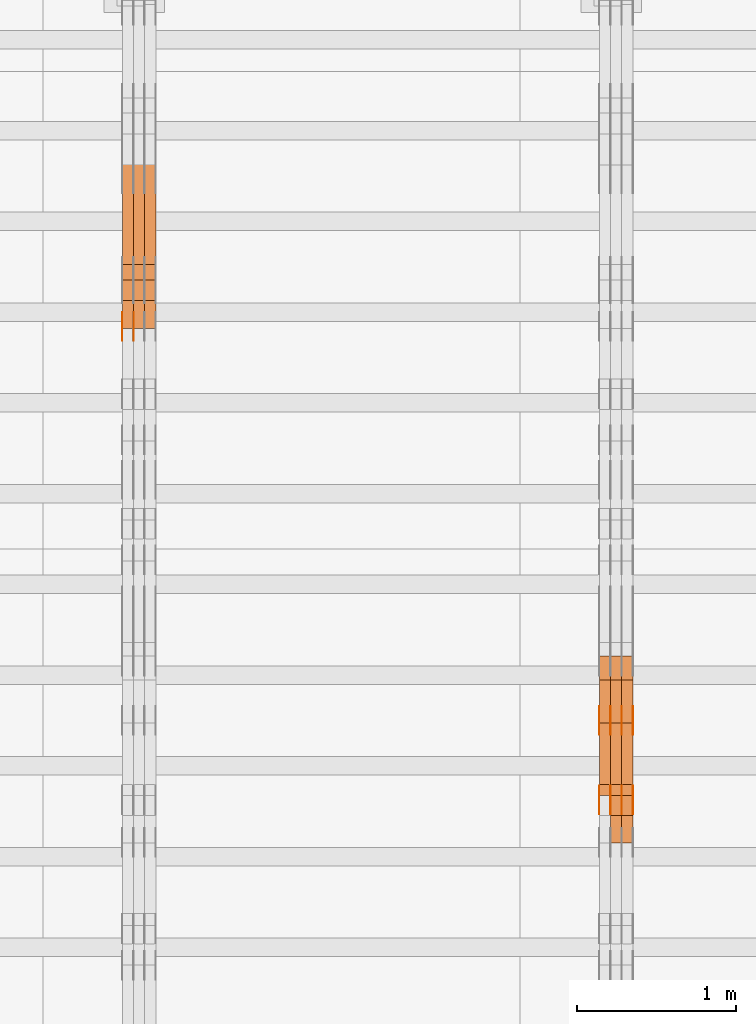
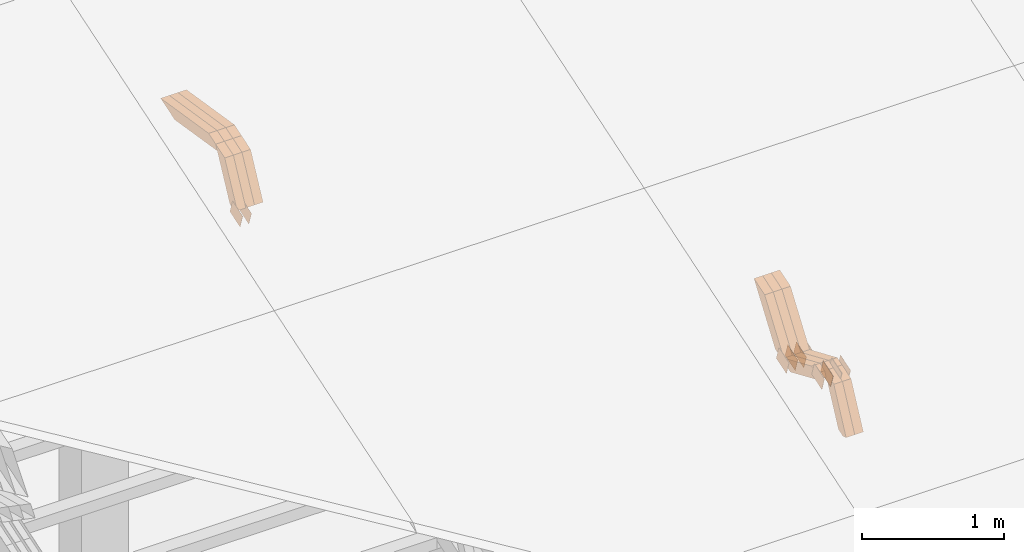
# One storey, part 138 of 385: 28 proxies.
"""IFC2X3 building model written with IfcOpenShell, lengths in millimetres."""

from ifc_helpers import new_model, entity, si_unit, converted_unit, derived_unit, direction, frame, origin, place, context, subcontext, project, spatial, polyline, outline, extrude, source, transform, mapped, material, type_object, type_shapes, element, save


model = new_model("IFC2X3")

# Units and contexts
model_context = context("Model", 3, precision=0.01, world=origin(), true_north=direction((6.12303176911189e-17, 1.0)))
body_context = subcontext(model_context, "Body", "Model", "MODEL_VIEW")
ifc_project = project(units=[si_unit("LENGTHUNIT", "METRE", prefix="MILLI"), si_unit("AREAUNIT", "SQUARE_METRE"), si_unit("VOLUMEUNIT", "CUBIC_METRE"), converted_unit("PLANEANGLEUNIT", "DEGREE", entity("IfcRatioMeasure", 0.0174532925199433), si_unit("PLANEANGLEUNIT", "RADIAN"), dimensions=[0, 0, 0, 0, 0, 0, 0]), si_unit("MASSUNIT", "GRAM", prefix="KILO"), derived_unit("MASSDENSITYUNIT", [(si_unit("MASSUNIT", "GRAM", prefix="KILO"), 1), (si_unit("LENGTHUNIT", "METRE"), -3)]), si_unit("TIMEUNIT", "SECOND"), si_unit("FREQUENCYUNIT", "HERTZ"), si_unit("THERMODYNAMICTEMPERATUREUNIT", "DEGREE_CELSIUS"), derived_unit("THERMALTRANSMITTANCEUNIT", [(si_unit("MASSUNIT", "GRAM", prefix="KILO"), 1), (si_unit("THERMODYNAMICTEMPERATUREUNIT", "KELVIN"), -1), (si_unit("TIMEUNIT", "SECOND"), -3)]), derived_unit("VOLUMETRICFLOWRATEUNIT", [(si_unit("LENGTHUNIT", "METRE"), 3), (si_unit("TIMEUNIT", "SECOND"), -1)]), si_unit("ELECTRICCURRENTUNIT", "AMPERE"), si_unit("ELECTRICVOLTAGEUNIT", "VOLT"), si_unit("POWERUNIT", "WATT"), si_unit("FORCEUNIT", "NEWTON", prefix="KILO"), si_unit("ILLUMINANCEUNIT", "LUX"), si_unit("LUMINOUSFLUXUNIT", "LUMEN"), si_unit("LUMINOUSINTENSITYUNIT", "CANDELA"), derived_unit("USERDEFINED", [(si_unit("MASSUNIT", "GRAM", prefix="KILO"), -1), (si_unit("LENGTHUNIT", "METRE"), -2), (si_unit("TIMEUNIT", "SECOND"), 3), (si_unit("LUMINOUSFLUXUNIT", "LUMEN"), 1)]), derived_unit("LINEARVELOCITYUNIT", [(si_unit("LENGTHUNIT", "METRE"), 1), (si_unit("TIMEUNIT", "SECOND"), -1)]), si_unit("PRESSUREUNIT", "PASCAL"), derived_unit("USERDEFINED", [(si_unit("LENGTHUNIT", "METRE"), -2), (si_unit("MASSUNIT", "GRAM", prefix="KILO"), 1), (si_unit("TIMEUNIT", "SECOND"), -2)])], contexts=[model_context])

# Site, building, storey
site_placement = place(None, origin())
site = spatial("IfcSite", under=ifc_project, at=site_placement, CompositionType="ELEMENT")
building_placement = place(site_placement, origin())
building = spatial("IfcBuilding", under=site, at=building_placement, CompositionType="ELEMENT")
storey_placement = place(building_placement, origin())
storey = spatial("IfcBuildingStorey", under=building, at=storey_placement, Name="Default", CompositionType="ELEMENT", Elevation=0.0)

# Proxies
ifc_material_1 = material(Name="IfcSurfaceStyle #379932")
building_element_proxy_type_1 = type_object("IfcBuildingElementProxyType", PredefinedType="NOTDEFINED", material=ifc_material_1)
shared_shape_1 = source(origin(), body_context, "Body", "SweptSolid", [
    extrude(outline(polyline([(-74.9998565677169, -60.0000596852269), (74.9998794200137, -60.0000596852269), (74.9998565677151, 60.0000596852269), (-74.9998794200119, 60.0000596852269), (-74.9998565677169, -60.0000596852269)])), frame((74.9998794200137, 60.0000596852269, 0.0), z_axis=(0.0, 0.0, 1.0), x_axis=(-1.0, 0.0, 0.0)), (0.0, 0.0, 1.0), 1.3),
])
type_shapes(building_element_proxy_type_1, [shared_shape_1])
proxy_1_placement = place(building_placement, frame((30386.3, 7527.6269081625, 1621.97418552253), z_axis=(-1.0, 0.0, 0.0), x_axis=(0.0, 0.951056516295124, 0.309016994375039)))
element("IfcBuildingElementProxy", 1, at=proxy_1_placement, inside=storey, type_object=building_element_proxy_type_1, material=ifc_material_1, context=body_context, shape_type="MappedRepresentation", body=[
    mapped(shared_shape_1, transform((0.0, 0.0, 0.0), scale=1.0)),
])
ifc_material_2 = material(Name="IfcSurfaceStyle #379875")
building_element_proxy_type_2 = type_object("IfcBuildingElementProxyType", PredefinedType="NOTDEFINED", material=ifc_material_2)
shared_shape_2 = source(origin(), body_context, "Body", "SweptSolid", [
    extrude(outline(polyline([(-74.9998565677169, -60.0000596852269), (74.9998794200137, -60.0000596852269), (74.9998565677151, 60.0000596852269), (-74.9998794200119, 60.0000596852269), (-74.9998565677169, -60.0000596852269)])), frame((74.9998794200137, 60.0000596852269, 0.0), z_axis=(0.0, 0.0, 1.0), x_axis=(-1.0, 0.0, 0.0)), (0.0, 0.0, 1.0), 1.3),
])
type_shapes(building_element_proxy_type_2, [shared_shape_2])
proxy_2_placement = place(building_placement, frame((30315.0, 7527.6269081625, 1621.97418552253), z_axis=(-1.0, 0.0, 0.0), x_axis=(0.0, 0.951056516295124, 0.309016994375039)))
element("IfcBuildingElementProxy", 2, at=proxy_2_placement, inside=storey, type_object=building_element_proxy_type_2, material=ifc_material_2, context=body_context, shape_type="MappedRepresentation", body=[
    mapped(shared_shape_2, transform((0.0, 0.0, 0.0), scale=1.0)),
])
ifc_material_3 = material(Name="IfcSurfaceStyle #379818")
building_element_proxy_type_3 = type_object("IfcBuildingElementProxyType", PredefinedType="NOTDEFINED", material=ifc_material_3)
shared_shape_3 = source(origin(), body_context, "Body", "SweptSolid", [
    extrude(outline(polyline([(-74.9998565677169, -60.0000596852269), (74.9998794200137, -60.0000596852269), (74.9998565677151, 60.0000596852269), (-74.9998794200119, 60.0000596852269), (-74.9998565677169, -60.0000596852269)])), frame((74.9998794200137, 60.0000596852269, 0.0), z_axis=(0.0, 0.0, 1.0), x_axis=(-1.0, 0.0, 0.0)), (0.0, 0.0, 1.0), 1.3),
])
type_shapes(building_element_proxy_type_3, [shared_shape_3])
proxy_3_placement = place(building_placement, frame((30316.3, 7527.6269081625, 1621.97418552253), z_axis=(-1.0, 0.0, 0.0), x_axis=(0.0, 0.951056516295124, 0.309016994375039)))
element("IfcBuildingElementProxy", 3, at=proxy_3_placement, inside=storey, type_object=building_element_proxy_type_3, material=ifc_material_3, context=body_context, shape_type="MappedRepresentation", body=[
    mapped(shared_shape_3, transform((0.0, 0.0, 0.0), scale=1.0)),
])
ifc_material_4 = material(Name="IfcSurfaceStyle #379761")
building_element_proxy_type_4 = type_object("IfcBuildingElementProxyType", PredefinedType="NOTDEFINED", material=ifc_material_4)
shared_shape_4 = source(origin(), body_context, "Body", "SweptSolid", [
    extrude(outline(polyline([(-74.9998565677169, -60.0000596852269), (74.9998794200137, -60.0000596852269), (74.9998565677151, 60.0000596852269), (-74.9998794200119, 60.0000596852269), (-74.9998565677169, -60.0000596852269)])), frame((74.9998794200137, 60.0000596852269, 0.0), z_axis=(0.0, 0.0, 1.0), x_axis=(-1.0, 0.0, 0.0)), (0.0, 0.0, 1.0), 1.29999999999999),
])
type_shapes(building_element_proxy_type_4, [shared_shape_4])
proxy_4_placement = place(building_placement, frame((30245.0, 7527.6269081625, 1621.97418552253), z_axis=(-1.0, 0.0, 0.0), x_axis=(0.0, 0.951056516295124, 0.309016994375039)))
element("IfcBuildingElementProxy", 4, at=proxy_4_placement, inside=storey, type_object=building_element_proxy_type_4, material=ifc_material_4, context=body_context, shape_type="MappedRepresentation", body=[
    mapped(shared_shape_4, transform((0.0, 0.0, 0.0), scale=1.0)),
])
ifc_material_5 = material(Name="IfcSurfaceStyle #379704")
building_element_proxy_type_5 = type_object("IfcBuildingElementProxyType", PredefinedType="NOTDEFINED", material=ifc_material_5)
shared_shape_5 = source(origin(), body_context, "Body", "SweptSolid", [
    extrude(outline(polyline([(-74.9998565677169, -60.0000596852269), (74.9998794200137, -60.0000596852269), (74.9998565677151, 60.0000596852269), (-74.9998794200119, 60.0000596852269), (-74.9998565677169, -60.0000596852269)])), frame((74.9998794200137, 60.0000596852269, 0.0), z_axis=(0.0, 0.0, 1.0), x_axis=(-1.0, 0.0, 0.0)), (0.0, 0.0, 1.0), 1.29999999999999),
])
type_shapes(building_element_proxy_type_5, [shared_shape_5])
proxy_5_placement = place(building_placement, frame((30246.3, 7527.6269081625, 1621.97418552253), z_axis=(-1.0, 0.0, 0.0), x_axis=(0.0, 0.951056516295124, 0.309016994375039)))
element("IfcBuildingElementProxy", 5, at=proxy_5_placement, inside=storey, type_object=building_element_proxy_type_5, material=ifc_material_5, context=body_context, shape_type="MappedRepresentation", body=[
    mapped(shared_shape_5, transform((0.0, 0.0, 0.0), scale=1.0)),
])
ifc_material_6 = material(Name="IfcSurfaceStyle #379647")
building_element_proxy_type_6 = type_object("IfcBuildingElementProxyType", PredefinedType="NOTDEFINED", material=ifc_material_6)
shared_shape_6 = source(origin(), body_context, "Body", "SweptSolid", [
    extrude(outline(polyline([(-74.9998565677169, -60.0000596852269), (74.9998794200137, -60.0000596852269), (74.9998565677151, 60.0000596852269), (-74.9998794200119, 60.0000596852269), (-74.9998565677169, -60.0000596852269)])), frame((74.9998794200137, 60.0000596852269, 0.0), z_axis=(0.0, 0.0, 1.0), x_axis=(-1.0, 0.0, 0.0)), (0.0, 0.0, 1.0), 1.29999999999999),
])
type_shapes(building_element_proxy_type_6, [shared_shape_6])
proxy_6_placement = place(building_placement, frame((30175.0, 7527.6269081625, 1621.97418552253), z_axis=(-1.0, 0.0, 0.0), x_axis=(0.0, 0.951056516295124, 0.309016994375039)))
element("IfcBuildingElementProxy", 6, at=proxy_6_placement, inside=storey, type_object=building_element_proxy_type_6, material=ifc_material_6, context=body_context, shape_type="MappedRepresentation", body=[
    mapped(shared_shape_6, transform((0.0, 0.0, 0.0), scale=1.0)),
])
ifc_material_7 = material(Name="IfcSurfaceStyle #369672")
building_element_proxy_type_7 = type_object("IfcBuildingElementProxyType", PredefinedType="NOTDEFINED", material=ifc_material_7)
shared_shape_7 = source(origin(), body_context, "Body", "SweptSolid", [
    extrude(outline(polyline([(-74.9998565677233, -60.0000596852342), (74.9998794200074, -60.0000596852342), (74.9998565677233, 60.0000596852342), (-74.9998794200074, 60.0000596852342), (-74.9998565677233, -60.0000596852342)])), frame((74.9998794200073, 60.0000596852342, 0.0), z_axis=(0.0, 0.0, 1.0), x_axis=(-1.0, 0.0, 0.0)), (0.0, 0.0, 1.0), 1.3),
])
type_shapes(building_element_proxy_type_7, [shared_shape_7])
proxy_7_placement = place(building_placement, frame((30386.3, 7029.15620503751, 1786.70025974129), z_axis=(-1.0, 0.0, 0.0), x_axis=(0.0, 0.951056516295154, 0.309016994374948)))
element("IfcBuildingElementProxy", 7, at=proxy_7_placement, inside=storey, type_object=building_element_proxy_type_7, material=ifc_material_7, context=body_context, shape_type="MappedRepresentation", body=[
    mapped(shared_shape_7, transform((0.0, 0.0, 0.0), scale=1.0)),
])
ifc_material_8 = material(Name="IfcSurfaceStyle #369615")
building_element_proxy_type_8 = type_object("IfcBuildingElementProxyType", PredefinedType="NOTDEFINED", material=ifc_material_8)
shared_shape_8 = source(origin(), body_context, "Body", "SweptSolid", [
    extrude(outline(polyline([(-74.9998565677233, -60.0000596852342), (74.9998794200074, -60.0000596852342), (74.9998565677233, 60.0000596852342), (-74.9998794200074, 60.0000596852342), (-74.9998565677233, -60.0000596852342)])), frame((74.9998794200073, 60.0000596852342, 0.0), z_axis=(0.0, 0.0, 1.0), x_axis=(-1.0, 0.0, 0.0)), (0.0, 0.0, 1.0), 1.3),
])
type_shapes(building_element_proxy_type_8, [shared_shape_8])
proxy_8_placement = place(building_placement, frame((30315.0, 7029.15620503751, 1786.70025974129), z_axis=(-1.0, 0.0, 0.0), x_axis=(0.0, 0.951056516295154, 0.309016994374948)))
element("IfcBuildingElementProxy", 8, at=proxy_8_placement, inside=storey, type_object=building_element_proxy_type_8, material=ifc_material_8, context=body_context, shape_type="MappedRepresentation", body=[
    mapped(shared_shape_8, transform((0.0, 0.0, 0.0), scale=1.0)),
])
ifc_material_9 = material(Name="IfcSurfaceStyle #369558")
building_element_proxy_type_9 = type_object("IfcBuildingElementProxyType", PredefinedType="NOTDEFINED", material=ifc_material_9)
shared_shape_9 = source(origin(), body_context, "Body", "SweptSolid", [
    extrude(outline(polyline([(-74.9998565677233, -60.0000596852342), (74.9998794200074, -60.0000596852342), (74.9998565677233, 60.0000596852342), (-74.9998794200074, 60.0000596852342), (-74.9998565677233, -60.0000596852342)])), frame((74.9998794200073, 60.0000596852342, 0.0), z_axis=(0.0, 0.0, 1.0), x_axis=(-1.0, 0.0, 0.0)), (0.0, 0.0, 1.0), 1.3),
])
type_shapes(building_element_proxy_type_9, [shared_shape_9])
proxy_9_placement = place(building_placement, frame((30316.3, 7029.15620503751, 1786.70025974129), z_axis=(-1.0, 0.0, 0.0), x_axis=(0.0, 0.951056516295154, 0.309016994374948)))
element("IfcBuildingElementProxy", 9, at=proxy_9_placement, inside=storey, type_object=building_element_proxy_type_9, material=ifc_material_9, context=body_context, shape_type="MappedRepresentation", body=[
    mapped(shared_shape_9, transform((0.0, 0.0, 0.0), scale=1.0)),
])
ifc_material_10 = material(Name="IfcSurfaceStyle #369501")
building_element_proxy_type_10 = type_object("IfcBuildingElementProxyType", PredefinedType="NOTDEFINED", material=ifc_material_10)
shared_shape_10 = source(origin(), body_context, "Body", "SweptSolid", [
    extrude(outline(polyline([(-74.9998565677233, -60.0000596852342), (74.9998794200074, -60.0000596852342), (74.9998565677233, 60.0000596852342), (-74.9998794200074, 60.0000596852342), (-74.9998565677233, -60.0000596852342)])), frame((74.9998794200073, 60.0000596852342, 0.0), z_axis=(0.0, 0.0, 1.0), x_axis=(-1.0, 0.0, 0.0)), (0.0, 0.0, 1.0), 1.29999999999999),
])
type_shapes(building_element_proxy_type_10, [shared_shape_10])
proxy_10_placement = place(building_placement, frame((30245.0, 7029.15620503751, 1786.70025974129), z_axis=(-1.0, 0.0, 0.0), x_axis=(0.0, 0.951056516295154, 0.309016994374948)))
element("IfcBuildingElementProxy", 10, at=proxy_10_placement, inside=storey, type_object=building_element_proxy_type_10, material=ifc_material_10, context=body_context, shape_type="MappedRepresentation", body=[
    mapped(shared_shape_10, transform((0.0, 0.0, 0.0), scale=1.0)),
])
ifc_material_11 = material(Name="IfcSurfaceStyle #369444")
building_element_proxy_type_11 = type_object("IfcBuildingElementProxyType", PredefinedType="NOTDEFINED", material=ifc_material_11)
shared_shape_11 = source(origin(), body_context, "Body", "SweptSolid", [
    extrude(outline(polyline([(-74.9998565677233, -60.0000596852342), (74.9998794200074, -60.0000596852342), (74.9998565677233, 60.0000596852342), (-74.9998794200074, 60.0000596852342), (-74.9998565677233, -60.0000596852342)])), frame((74.9998794200073, 60.0000596852342, 0.0), z_axis=(0.0, 0.0, 1.0), x_axis=(-1.0, 0.0, 0.0)), (0.0, 0.0, 1.0), 1.29999999999999),
])
type_shapes(building_element_proxy_type_11, [shared_shape_11])
proxy_11_placement = place(building_placement, frame((30246.3, 7029.15620503751, 1786.70025974129), z_axis=(-1.0, 0.0, 0.0), x_axis=(0.0, 0.951056516295154, 0.309016994374948)))
element("IfcBuildingElementProxy", 11, at=proxy_11_placement, inside=storey, type_object=building_element_proxy_type_11, material=ifc_material_11, context=body_context, shape_type="MappedRepresentation", body=[
    mapped(shared_shape_11, transform((0.0, 0.0, 0.0), scale=1.0)),
])
ifc_material_12 = material(Name="IfcSurfaceStyle #369387")
building_element_proxy_type_12 = type_object("IfcBuildingElementProxyType", PredefinedType="NOTDEFINED", material=ifc_material_12)
shared_shape_12 = source(origin(), body_context, "Body", "SweptSolid", [
    extrude(outline(polyline([(-74.9998565677233, -60.0000596852342), (74.9998794200074, -60.0000596852342), (74.9998565677233, 60.0000596852342), (-74.9998794200074, 60.0000596852342), (-74.9998565677233, -60.0000596852342)])), frame((74.9998794200073, 60.0000596852342, 0.0), z_axis=(0.0, 0.0, 1.0), x_axis=(-1.0, 0.0, 0.0)), (0.0, 0.0, 1.0), 1.29999999999999),
])
type_shapes(building_element_proxy_type_12, [shared_shape_12])
proxy_12_placement = place(building_placement, frame((30175.0, 7029.15620503751, 1786.70025974129), z_axis=(-1.0, 0.0, 0.0), x_axis=(0.0, 0.951056516295154, 0.309016994374948)))
element("IfcBuildingElementProxy", 12, at=proxy_12_placement, inside=storey, type_object=building_element_proxy_type_12, material=ifc_material_12, context=body_context, shape_type="MappedRepresentation", body=[
    mapped(shared_shape_12, transform((0.0, 0.0, 0.0), scale=1.0)),
])
ifc_material_13 = material(Name="IfcSurfaceStyle #357180")
building_element_proxy_type_13 = type_object("IfcBuildingElementProxyType", Name="T1-W17 357178", PredefinedType="NOTDEFINED", material=ifc_material_13)
shared_shape_13 = source(origin(), body_context, "Body", "SweptSolid", [
    extrude(outline(polyline([(-364.271754334175, -47.5002955168173), (154.762247185537, -47.5002955168173), (218.32500198375, 4.1746158945366e-05), (228.330650189718, 47.5002746437378), (-237.14614502483, 47.5002746437378), (-364.271754334175, -47.5002955168173)])), frame((228.330650189718, 47.5002746437378, 0.0), z_axis=(0.0, 0.0, 1.0), x_axis=(-1.0, 0.0, 0.0)), (0.0, 0.0, 1.0), 70.0),
])
type_shapes(building_element_proxy_type_13, [shared_shape_13])
proxy_13_placement = place(building_placement, frame((30385.0, 7603.591796875, 1617.27880859375), z_axis=(-1.0, 0.0, 0.0), x_axis=(0.0, 0.576852646364743, 0.816848226038346)))
element("IfcBuildingElementProxy", 13, at=proxy_13_placement, inside=storey, type_object=building_element_proxy_type_13, material=ifc_material_13, Name="T1-W17", context=body_context, shape_type="MappedRepresentation", body=[
    mapped(shared_shape_13, transform((0.0, 0.0, 0.0), scale=1.0)),
])
ifc_material_14 = material(Name="IfcSurfaceStyle #357114")
building_element_proxy_type_14 = type_object("IfcBuildingElementProxyType", Name="T1-W17 357112", PredefinedType="NOTDEFINED", material=ifc_material_14)
shared_shape_14 = source(origin(), body_context, "Body", "SweptSolid", [
    extrude(outline(polyline([(-364.271754334175, -47.5002955168173), (154.762247185537, -47.5002955168173), (218.32500198375, 4.1746158945366e-05), (228.330650189718, 47.5002746437378), (-237.14614502483, 47.5002746437378), (-364.271754334175, -47.5002955168173)])), frame((228.330650189718, 47.5002746437378, 0.0), z_axis=(0.0, 0.0, 1.0), x_axis=(-1.0, 0.0, 0.0)), (0.0, 0.0, 1.0), 70.0),
])
type_shapes(building_element_proxy_type_14, [shared_shape_14])
proxy_14_placement = place(building_placement, frame((30315.0, 7603.591796875, 1617.27880859375), z_axis=(-1.0, 0.0, 0.0), x_axis=(0.0, 0.576852646364743, 0.816848226038346)))
element("IfcBuildingElementProxy", 14, at=proxy_14_placement, inside=storey, type_object=building_element_proxy_type_14, material=ifc_material_14, Name="T1-W17", context=body_context, shape_type="MappedRepresentation", body=[
    mapped(shared_shape_14, transform((0.0, 0.0, 0.0), scale=1.0)),
])
ifc_material_15 = material(Name="IfcSurfaceStyle #357048")
building_element_proxy_type_15 = type_object("IfcBuildingElementProxyType", Name="T1-W17 357046", PredefinedType="NOTDEFINED", material=ifc_material_15)
shared_shape_15 = source(origin(), body_context, "Body", "SweptSolid", [
    extrude(outline(polyline([(-364.271754334175, -47.5002955168173), (154.762247185537, -47.5002955168173), (218.32500198375, 4.1746158945366e-05), (228.330650189718, 47.5002746437378), (-237.14614502483, 47.5002746437378), (-364.271754334175, -47.5002955168173)])), frame((228.330650189718, 47.5002746437378, 0.0), z_axis=(0.0, 0.0, 1.0), x_axis=(-1.0, 0.0, 0.0)), (0.0, 0.0, 1.0), 70.0),
])
type_shapes(building_element_proxy_type_15, [shared_shape_15])
proxy_15_placement = place(building_placement, frame((30245.0, 7603.591796875, 1617.27880859375), z_axis=(-1.0, 0.0, 0.0), x_axis=(0.0, 0.576852646364743, 0.816848226038346)))
element("IfcBuildingElementProxy", 15, at=proxy_15_placement, inside=storey, type_object=building_element_proxy_type_15, material=ifc_material_15, Name="T1-W17", context=body_context, shape_type="MappedRepresentation", body=[
    mapped(shared_shape_15, transform((0.0, 0.0, 0.0), scale=1.0)),
])
ifc_material_16 = material(Name="IfcSurfaceStyle #356784")
building_element_proxy_type_16 = type_object("IfcBuildingElementProxyType", Name="T1-W28 356782", PredefinedType="NOTDEFINED", material=ifc_material_16)
shared_shape_16 = source(origin(), body_context, "Body", "SweptSolid", [
    extrude(outline(polyline([(-217.926999432742, -47.5002417204892), (200.85556309928, -47.5002417204892), (198.503183549447, 8.27993157516647e-05), (144.500539771884, 47.5002003208314), (-325.932286987868, 47.5002003208314), (-217.926999432742, -47.5002417204892)])), frame((200.855855188284, 47.5002003208314, 0.0), z_axis=(0.0, 0.0, 1.0), x_axis=(-1.0, 0.0, 0.0)), (0.0, 0.0, 1.0), 70.0),
])
type_shapes(building_element_proxy_type_16, [shared_shape_16])
proxy_16_placement = place(building_placement, frame((30385.0, 7164.46308589723, 1806.71154838415), z_axis=(-1.0, 0.0, 0.0), x_axis=(0.0, 0.918207947119617, -0.396098681954861)))
element("IfcBuildingElementProxy", 16, at=proxy_16_placement, inside=storey, type_object=building_element_proxy_type_16, material=ifc_material_16, Name="T1-W28", context=body_context, shape_type="MappedRepresentation", body=[
    mapped(shared_shape_16, transform((0.0, 0.0, 0.0), scale=1.0)),
])
ifc_material_17 = material(Name="IfcSurfaceStyle #356718")
building_element_proxy_type_17 = type_object("IfcBuildingElementProxyType", Name="T1-W28 356716", PredefinedType="NOTDEFINED", material=ifc_material_17)
shared_shape_17 = source(origin(), body_context, "Body", "SweptSolid", [
    extrude(outline(polyline([(-217.926999432742, -47.5002417204892), (200.85556309928, -47.5002417204892), (198.503183549447, 8.27993157516647e-05), (144.500539771884, 47.5002003208314), (-325.932286987868, 47.5002003208314), (-217.926999432742, -47.5002417204892)])), frame((200.855855188284, 47.5002003208314, 0.0), z_axis=(0.0, 0.0, 1.0), x_axis=(-1.0, 0.0, 0.0)), (0.0, 0.0, 1.0), 70.0),
])
type_shapes(building_element_proxy_type_17, [shared_shape_17])
proxy_17_placement = place(building_placement, frame((30315.0, 7164.46308589723, 1806.71154838415), z_axis=(-1.0, 0.0, 0.0), x_axis=(0.0, 0.918207947119617, -0.396098681954861)))
element("IfcBuildingElementProxy", 17, at=proxy_17_placement, inside=storey, type_object=building_element_proxy_type_17, material=ifc_material_17, Name="T1-W28", context=body_context, shape_type="MappedRepresentation", body=[
    mapped(shared_shape_17, transform((0.0, 0.0, 0.0), scale=1.0)),
])
ifc_material_18 = material(Name="IfcSurfaceStyle #356652")
building_element_proxy_type_18 = type_object("IfcBuildingElementProxyType", Name="T1-W28 356650", PredefinedType="NOTDEFINED", material=ifc_material_18)
shared_shape_18 = source(origin(), body_context, "Body", "SweptSolid", [
    extrude(outline(polyline([(-217.926999432742, -47.5002417204892), (200.85556309928, -47.5002417204892), (198.503183549447, 8.27993157516647e-05), (144.500539771884, 47.5002003208314), (-325.932286987868, 47.5002003208314), (-217.926999432742, -47.5002417204892)])), frame((200.855855188284, 47.5002003208314, 0.0), z_axis=(0.0, 0.0, 1.0), x_axis=(-1.0, 0.0, 0.0)), (0.0, 0.0, 1.0), 70.0),
])
type_shapes(building_element_proxy_type_18, [shared_shape_18])
proxy_18_placement = place(building_placement, frame((30245.0, 7164.46308589723, 1806.71154838415), z_axis=(-1.0, 0.0, 0.0), x_axis=(0.0, 0.918207947119617, -0.396098681954861)))
element("IfcBuildingElementProxy", 18, at=proxy_18_placement, inside=storey, type_object=building_element_proxy_type_18, material=ifc_material_18, Name="T1-W28", context=body_context, shape_type="MappedRepresentation", body=[
    mapped(shared_shape_18, transform((0.0, 0.0, 0.0), scale=1.0)),
])
ifc_material_19 = material(Name="IfcSurfaceStyle #356388")
building_element_proxy_type_19 = type_object("IfcBuildingElementProxyType", Name="T1-W38 356386", PredefinedType="NOTDEFINED", material=ifc_material_19)
shared_shape_19 = source(origin(), body_context, "Body", "SweptSolid", [
    extrude(outline(polyline([(-298.027186733919, -47.5000251939178), (135.138415004037, -47.5000251939178), (181.282052802132, 0.000918984287993996), (187.347601017465, 47.4995657017738), (-205.740882089715, 47.4995657017739), (-298.027186733919, -47.5000251939178)])), frame((187.347846776827, 47.5001085012031, 0.0), z_axis=(0.0, 0.0, 1.0), x_axis=(-1.0, 0.0, 0.0)), (0.0, 0.0, 1.0), 70.0),
])
type_shapes(building_element_proxy_type_19, [shared_shape_19])
proxy_19_placement = place(building_placement, frame((30385.0, 6848.47987320449, 1368.44362234215), z_axis=(-1.0, 0.0, 0.0), x_axis=(0.0, 0.441034274474743, 0.897490261082836)))
element("IfcBuildingElementProxy", 19, at=proxy_19_placement, inside=storey, type_object=building_element_proxy_type_19, material=ifc_material_19, Name="T1-W38", context=body_context, shape_type="MappedRepresentation", body=[
    mapped(shared_shape_19, transform((0.0, 0.0, 0.0), scale=1.0)),
])
ifc_material_20 = material(Name="IfcSurfaceStyle #356322")
building_element_proxy_type_20 = type_object("IfcBuildingElementProxyType", Name="T1-W38 356320", PredefinedType="NOTDEFINED", material=ifc_material_20)
shared_shape_20 = source(origin(), body_context, "Body", "SweptSolid", [
    extrude(outline(polyline([(-298.027186733919, -47.5000251939178), (135.138415004037, -47.5000251939178), (181.282052802132, 0.000918984287993996), (187.347601017465, 47.4995657017738), (-205.740882089715, 47.4995657017739), (-298.027186733919, -47.5000251939178)])), frame((187.347846776827, 47.5001085012031, 0.0), z_axis=(0.0, 0.0, 1.0), x_axis=(-1.0, 0.0, 0.0)), (0.0, 0.0, 1.0), 70.0),
])
type_shapes(building_element_proxy_type_20, [shared_shape_20])
proxy_20_placement = place(building_placement, frame((30315.0, 6848.47987320449, 1368.44362234215), z_axis=(-1.0, 0.0, 0.0), x_axis=(0.0, 0.441034274474743, 0.897490261082836)))
element("IfcBuildingElementProxy", 20, at=proxy_20_placement, inside=storey, type_object=building_element_proxy_type_20, material=ifc_material_20, Name="T1-W38", context=body_context, shape_type="MappedRepresentation", body=[
    mapped(shared_shape_20, transform((0.0, 0.0, 0.0), scale=1.0)),
])
ifc_material_21 = material(Name="IfcSurfaceStyle #345614")
building_element_proxy_type_21 = type_object("IfcBuildingElementProxyType", PredefinedType="NOTDEFINED", material=ifc_material_21)
shared_shape_21 = source(origin(), body_context, "Body", "SweptSolid", [
    extrude(outline(polyline([(-74.9998754286189, -60.0000016373433), (74.9998605591118, -60.0000016373433), (74.9998754286189, 60.0000016373433), (-74.9998605591118, 60.0000016373433), (-74.9998754286189, -60.0000016373433)])), frame((74.9999131819004, 60.0000016373433, 0.0), z_axis=(0.0, 0.0, 1.0), x_axis=(-1.0, 0.0, 0.0)), (0.0, 0.0, 1.0), 1.29999999999999),
])
type_shapes(building_element_proxy_type_21, [shared_shape_21])
proxy_21_placement = place(building_placement, frame((27246.3, 10004.8612689908, 2426.87628052724), z_axis=(-1.0, 0.0, 0.0), x_axis=(0.0, 0.951056516295124, 0.309016994375039)))
element("IfcBuildingElementProxy", 21, at=proxy_21_placement, inside=storey, type_object=building_element_proxy_type_21, material=ifc_material_21, context=body_context, shape_type="MappedRepresentation", body=[
    mapped(shared_shape_21, transform((0.0, 0.0, 0.0), scale=1.0)),
])
ifc_material_22 = material(Name="IfcSurfaceStyle #345557")
building_element_proxy_type_22 = type_object("IfcBuildingElementProxyType", PredefinedType="NOTDEFINED", material=ifc_material_22)
shared_shape_22 = source(origin(), body_context, "Body", "SweptSolid", [
    extrude(outline(polyline([(-74.9998754286189, -60.0000016373433), (74.9998605591118, -60.0000016373433), (74.9998754286189, 60.0000016373433), (-74.9998605591118, 60.0000016373433), (-74.9998754286189, -60.0000016373433)])), frame((74.9999131819004, 60.0000016373433, 0.0), z_axis=(0.0, 0.0, 1.0), x_axis=(-1.0, 0.0, 0.0)), (0.0, 0.0, 1.0), 1.29999999999999),
])
type_shapes(building_element_proxy_type_22, [shared_shape_22])
proxy_22_placement = place(building_placement, frame((27175.0, 10004.8612689908, 2426.87628052724), z_axis=(-1.0, 0.0, 0.0), x_axis=(0.0, 0.951056516295124, 0.309016994375039)))
element("IfcBuildingElementProxy", 22, at=proxy_22_placement, inside=storey, type_object=building_element_proxy_type_22, material=ifc_material_22, context=body_context, shape_type="MappedRepresentation", body=[
    mapped(shared_shape_22, transform((0.0, 0.0, 0.0), scale=1.0)),
])
ifc_material_23 = material(Name="IfcSurfaceStyle #325520")
building_element_proxy_type_23 = type_object("IfcBuildingElementProxyType", Name="T1-W5 325518", PredefinedType="NOTDEFINED", material=ifc_material_23)
shared_shape_23 = source(origin(), body_context, "Body", "SweptSolid", [
    extrude(outline(polyline([(-301.214270081322, -47.5000783565111), (303.980395954293, -47.5000783565111), (288.664123931657, 0.000197935560590153), (195.704076557203, 47.4999793887309), (-487.134326361831, 47.4999793887309), (-301.214270081322, -47.5000783565111)])), frame((303.980395954293, 47.5001815410909, 0.0), z_axis=(0.0, 0.0, 1.0), x_axis=(-1.0, 0.0, 0.0)), (0.0, 0.0, 1.0), 70.0),
])
type_shapes(building_element_proxy_type_23, [shared_shape_23])
proxy_23_placement = place(building_placement, frame((27385.0, 10379.2051671398, 2863.91176079486), z_axis=(-1.0, 0.0, 0.0), x_axis=(0.0, 0.987508363398486, -0.1575665961365)))
element("IfcBuildingElementProxy", 23, at=proxy_23_placement, inside=storey, type_object=building_element_proxy_type_23, material=ifc_material_23, Name="T1-W5", context=body_context, shape_type="MappedRepresentation", body=[
    mapped(shared_shape_23, transform((0.0, 0.0, 0.0), scale=1.0)),
])
ifc_material_24 = material(Name="IfcSurfaceStyle #325454")
building_element_proxy_type_24 = type_object("IfcBuildingElementProxyType", Name="T1-W5 325452", PredefinedType="NOTDEFINED", material=ifc_material_24)
shared_shape_24 = source(origin(), body_context, "Body", "SweptSolid", [
    extrude(outline(polyline([(-301.214270081322, -47.5000783565111), (303.980395954293, -47.5000783565111), (288.664123931657, 0.000197935560590153), (195.704076557203, 47.4999793887309), (-487.134326361831, 47.4999793887309), (-301.214270081322, -47.5000783565111)])), frame((303.980395954293, 47.5001815410909, 0.0), z_axis=(0.0, 0.0, 1.0), x_axis=(-1.0, 0.0, 0.0)), (0.0, 0.0, 1.0), 70.0),
])
type_shapes(building_element_proxy_type_24, [shared_shape_24])
proxy_24_placement = place(building_placement, frame((27315.0, 10379.2051671398, 2863.91176079486), z_axis=(-1.0, 0.0, 0.0), x_axis=(0.0, 0.987508363398486, -0.1575665961365)))
element("IfcBuildingElementProxy", 24, at=proxy_24_placement, inside=storey, type_object=building_element_proxy_type_24, material=ifc_material_24, Name="T1-W5", context=body_context, shape_type="MappedRepresentation", body=[
    mapped(shared_shape_24, transform((0.0, 0.0, 0.0), scale=1.0)),
])
ifc_material_25 = material(Name="IfcSurfaceStyle #325388")
building_element_proxy_type_25 = type_object("IfcBuildingElementProxyType", Name="T1-W5 325386", PredefinedType="NOTDEFINED", material=ifc_material_25)
shared_shape_25 = source(origin(), body_context, "Body", "SweptSolid", [
    extrude(outline(polyline([(-301.214270081322, -47.5000783565111), (303.980395954293, -47.5000783565111), (288.664123931657, 0.000197935560590153), (195.704076557203, 47.4999793887309), (-487.134326361831, 47.4999793887309), (-301.214270081322, -47.5000783565111)])), frame((303.980395954293, 47.5001815410909, 0.0), z_axis=(0.0, 0.0, 1.0), x_axis=(-1.0, 0.0, 0.0)), (0.0, 0.0, 1.0), 70.0),
])
type_shapes(building_element_proxy_type_25, [shared_shape_25])
proxy_25_placement = place(building_placement, frame((27245.0, 10379.2051671398, 2863.91176079486), z_axis=(-1.0, 0.0, 0.0), x_axis=(0.0, 0.987508363398486, -0.1575665961365)))
element("IfcBuildingElementProxy", 25, at=proxy_25_placement, inside=storey, type_object=building_element_proxy_type_25, material=ifc_material_25, Name="T1-W5", context=body_context, shape_type="MappedRepresentation", body=[
    mapped(shared_shape_25, transform((0.0, 0.0, 0.0), scale=1.0)),
])
ifc_material_26 = material(Name="IfcSurfaceStyle #325124")
building_element_proxy_type_26 = type_object("IfcBuildingElementProxyType", Name="T1-W37 325122", PredefinedType="NOTDEFINED", material=ifc_material_26)
shared_shape_26 = source(origin(), body_context, "Body", "SweptSolid", [
    extrude(outline(polyline([(111.787482004227, -179.289397746839), (245.990585035629, -179.289397746839), (-64.0177573255029, 131.410401861866), (-131.116409377007, 131.410958895698), (-162.643900337347, 95.757434736113), (111.787482004227, -179.289397746839)])), frame((185.635323570343, 47.5011799885346, 0.0), z_axis=(0.0, 0.0, 1.0), x_axis=(0.706316677358935, 0.707896003156279, 0.0)), (0.0, 0.0, 1.0), 70.0),
])
type_shapes(building_element_proxy_type_26, [shared_shape_26])
proxy_26_placement = place(building_placement, frame((27385.0, 10081.8581176196, 2424.08390440728), z_axis=(-1.0, 0.0, 0.0), x_axis=(0.0, 0.452995827831714, 0.891512635898707)))
element("IfcBuildingElementProxy", 26, at=proxy_26_placement, inside=storey, type_object=building_element_proxy_type_26, material=ifc_material_26, Name="T1-W37", context=body_context, shape_type="MappedRepresentation", body=[
    mapped(shared_shape_26, transform((0.0, 0.0, 0.0), scale=1.0)),
])
ifc_material_27 = material(Name="IfcSurfaceStyle #325058")
building_element_proxy_type_27 = type_object("IfcBuildingElementProxyType", Name="T1-W37 325056", PredefinedType="NOTDEFINED", material=ifc_material_27)
shared_shape_27 = source(origin(), body_context, "Body", "SweptSolid", [
    extrude(outline(polyline([(111.787482004227, -179.289397746839), (245.990585035629, -179.289397746839), (-64.0177573255029, 131.410401861866), (-131.116409377007, 131.410958895698), (-162.643900337347, 95.757434736113), (111.787482004227, -179.289397746839)])), frame((185.635323570343, 47.5011799885346, 0.0), z_axis=(0.0, 0.0, 1.0), x_axis=(0.706316677358935, 0.707896003156279, 0.0)), (0.0, 0.0, 1.0), 70.0),
])
type_shapes(building_element_proxy_type_27, [shared_shape_27])
proxy_27_placement = place(building_placement, frame((27315.0, 10081.8581176196, 2424.08390440728), z_axis=(-1.0, 0.0, 0.0), x_axis=(0.0, 0.452995827831714, 0.891512635898707)))
element("IfcBuildingElementProxy", 27, at=proxy_27_placement, inside=storey, type_object=building_element_proxy_type_27, material=ifc_material_27, Name="T1-W37", context=body_context, shape_type="MappedRepresentation", body=[
    mapped(shared_shape_27, transform((0.0, 0.0, 0.0), scale=1.0)),
])
ifc_material_28 = material(Name="IfcSurfaceStyle #324992")
building_element_proxy_type_28 = type_object("IfcBuildingElementProxyType", Name="T1-W37 324990", PredefinedType="NOTDEFINED", material=ifc_material_28)
shared_shape_28 = source(origin(), body_context, "Body", "SweptSolid", [
    extrude(outline(polyline([(111.787482004227, -179.289397746839), (245.990585035629, -179.289397746839), (-64.0177573255029, 131.410401861866), (-131.116409377007, 131.410958895698), (-162.643900337347, 95.757434736113), (111.787482004227, -179.289397746839)])), frame((185.635323570343, 47.5011799885346, 0.0), z_axis=(0.0, 0.0, 1.0), x_axis=(0.706316677358935, 0.707896003156279, 0.0)), (0.0, 0.0, 1.0), 70.0),
])
type_shapes(building_element_proxy_type_28, [shared_shape_28])
proxy_28_placement = place(building_placement, frame((27245.0, 10081.8581176196, 2424.08390440728), z_axis=(-1.0, 0.0, 0.0), x_axis=(0.0, 0.452995827831714, 0.891512635898707)))
element("IfcBuildingElementProxy", 28, at=proxy_28_placement, inside=storey, type_object=building_element_proxy_type_28, material=ifc_material_28, Name="T1-W37", context=body_context, shape_type="MappedRepresentation", body=[
    mapped(shared_shape_28, transform((0.0, 0.0, 0.0), scale=1.0)),
])

save(model, "model.ifc")
